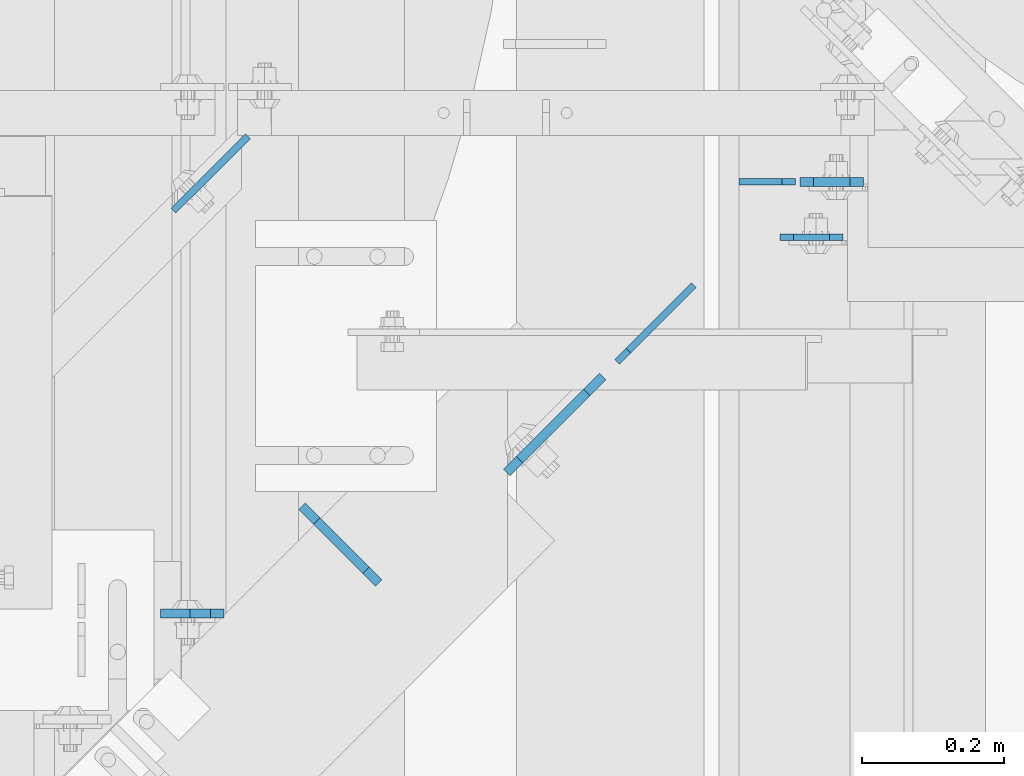
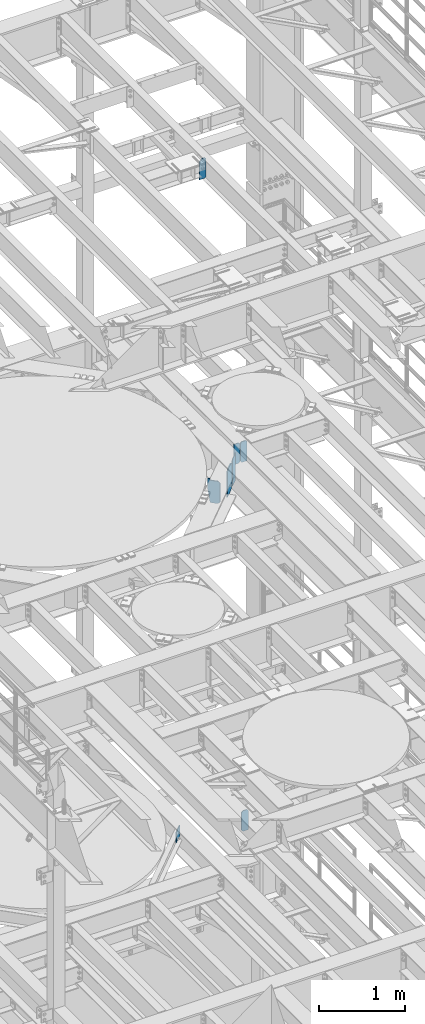
# One storey, part 1786 of 1876: 8 plates, 6 elements without a shape of their own.
"""IFC2X3 building model written with IfcOpenShell, lengths in millimetres."""

from ifc_helpers import new_model, si_unit, frame, origin_with_axes, place, context, subcontext, project, spatial, faceted_brep, material, type_object, element, aggregate, save


model = new_model("IFC2X3")

# Units and contexts
model_context = context("Model", 3, precision=1e-05, world=origin_with_axes())
body_context = subcontext(model_context, "Body", "Model", "MODEL_VIEW")
ifc_project = project(units=[si_unit("LENGTHUNIT", "METRE", prefix="MILLI"), si_unit("AREAUNIT", "SQUARE_METRE"), si_unit("VOLUMEUNIT", "CUBIC_METRE"), si_unit("MASSUNIT", "GRAM", prefix="KILO"), si_unit("TIMEUNIT", "SECOND"), si_unit("PLANEANGLEUNIT", "RADIAN"), si_unit("SOLIDANGLEUNIT", "STERADIAN"), si_unit("THERMODYNAMICTEMPERATUREUNIT", "DEGREE_CELSIUS"), si_unit("LUMINOUSINTENSITYUNIT", "LUMEN")], contexts=[model_context])

# Site, building, storey
site_placement = place(None, origin_with_axes())
site = spatial("IfcSite", under=ifc_project, at=site_placement, CompositionType="ELEMENT")
building_placement = place(site_placement, origin_with_axes())
building = spatial("IfcBuilding", under=site, at=building_placement, Name="Undefined", CompositionType="ELEMENT")
storey_placement = place(building_placement, origin_with_axes())
storey = spatial("IfcBuildingStorey", under=building, at=storey_placement, Name="Undefined", CompositionType="ELEMENT", Elevation=0.0)

# Assembly, plate
assembly_1_placement = place(storey_placement, origin_with_axes())
assembly_1 = element("IfcElementAssembly", 1, at=assembly_1_placement, inside=storey, Name="BEAM", AssemblyPlace="NOTDEFINED", PredefinedType="RIGID_FRAME")
ifc_material = material(Name="STEEL/A36")
plate_type_1 = type_object("IfcPlateType", PredefinedType="NOTDEFINED")
plate_1_placement = place(assembly_1_placement, frame((5489.575, 10802.9379999161, 7851.775), z_axis=(0.0, 0.0, 1.0), x_axis=(1.0, 0.0, 0.0)))
plate_1 = element("IfcPlate", 2, at=plate_1_placement, type_object=plate_type_1, material=ifc_material, Name="PLATE", context=body_context, shape_type="Brep", body=[
    faceted_brep([(0.0, -4.76249999999982, 19.0499992370605), (0.0, -4.76249999999982, 271.462512969971), (0.0, 4.76249999999982, 271.462512969971), (0.0, 4.76249999999982, 19.0499992370605), (19.0499992370605, -4.76249999999982, 290.512512207031), (19.0499992370605, 4.76249999999982, 290.512512207031), (69.8500022888184, -4.76250000000073, 290.512512207031), (69.8500022888184, 4.76250000000073, 290.512512207031), (88.9000015258789, -4.76250000000073, 271.462512969971), (88.9000015258789, 4.76250000000073, 271.462512969971), (88.9000015258789, -4.76249999999982, 0.0), (88.9000015258789, 4.76249999999982, 0.0), (19.0499992370605, -4.76249999999982, 0.0), (19.0499992370605, 4.76249999999982, 0.0)], [[[0, 1, 2, 3]], [[1, 4, 5, 2]], [[4, 6, 7, 5]], [[6, 8, 9, 7]], [[8, 10, 11, 9]], [[10, 12, 13, 11]], [[12, 0, 3, 13]], [[5, 7, 9, 11, 13, 3, 2]], [[12, 10, 8, 6, 4, 1, 0]]]),
])
aggregate(assembly_1, [plate_1])

assembly_2_placement = place(storey_placement, origin_with_axes())
assembly_2 = element("IfcElementAssembly", 3, at=assembly_2_placement, inside=storey, Name="BEAM", AssemblyPlace="NOTDEFINED", PredefinedType="RIGID_FRAME")
plate_type_2 = type_object("IfcPlateType", PredefinedType="NOTDEFINED")
plate_2_placement = place(assembly_2_placement, frame((4708.525, 10274.3012879372, 17686.3375), z_axis=(0.0, 0.0, 1.0), x_axis=(-1.0, 0.0, 0.0)))
plate_2 = element("IfcPlate", 4, at=plate_2_placement, type_object=plate_type_2, material=ifc_material, Name="PLATE", context=body_context, shape_type="Brep", body=[
    faceted_brep([(0.0, -6.35000000000036, 271.462512969971), (19.0499992370605, -6.35000000000036, 290.512512207031), (19.0499992370605, 6.35000000000036, 290.512512207031), (0.0, 6.35000000000036, 271.462512969971), (0.0, -6.35000000000196, 19.0499992370605), (0.0, 6.35000000000105, 19.0499992370605), (19.0499992370642, -6.35000000000105, 0.0), (19.0499992370633, 6.35000000000105, 0.0), (88.9000015258789, -6.34999999999991, 0.0), (88.9000015258789, 6.34999999999991, 0.0), (88.9000015258789, -6.35000000000036, 249.237510681152), (47.625, -6.35000000000036, 290.512512207031), (47.625, 6.35000000000036, 290.512512207031), (88.9000015258789, 6.35000000000036, 249.237510681152)], [[[0, 1, 2, 3]], [[4, 0, 3, 5]], [[6, 4, 5, 7]], [[8, 6, 7, 9]], [[6, 8, 10, 11, 1, 0, 4]], [[1, 11, 12, 2]], [[2, 12, 13, 9, 7, 5, 3]], [[10, 8, 9, 13]], [[11, 10, 13, 12]]]),
])
aggregate(assembly_2, [plate_2])

# Assembly, plates
assembly_3_placement = place(storey_placement, origin_with_axes())
assembly_3 = element("IfcElementAssembly", 5, at=assembly_3_placement, inside=storey, Name="BEAM", AssemblyPlace="NOTDEFINED", PredefinedType="RIGID_FRAME")
plate_3_placement = place(assembly_3_placement, frame((5518.15, 10880.6721065215, 13007.975), z_axis=(0.0, 0.0, 1.0), x_axis=(1.0, 0.0, 0.0)))
plate_3 = element("IfcPlate", 6, at=plate_3_placement, type_object=plate_type_2, material=ifc_material, Name="PLATE", context=body_context, shape_type="Brep", body=[
    faceted_brep([(0.0, -6.35000000000196, 19.0499992370605), (0.0, -6.35000000000036, 271.462512969971), (0.0, 6.35000000000036, 271.462512969971), (0.0, 6.35000000000105, 19.0499992370605), (19.0499992370605, -6.35000000000036, 290.512512207031), (19.0499992370605, 6.35000000000036, 290.512512207031), (69.8500003814697, -6.34999999999991, 290.512512207031), (69.8500003814697, 6.34999999999991, 290.512512207031), (88.9000015258789, -6.35000000000036, 271.462512969971), (88.9000015258789, 6.35000000000036, 271.462512969971), (88.9000015258789, -6.34999999999991, 0.0), (88.9000015258789, 6.34999999999991, 0.0), (19.0499992370642, -6.35000000000105, 0.0), (19.0499992370633, 6.35000000000105, 0.0)], [[[0, 1, 2, 3]], [[1, 4, 5, 2]], [[4, 6, 7, 5]], [[6, 8, 9, 7]], [[8, 10, 11, 9]], [[10, 12, 13, 11]], [[12, 0, 3, 13]], [[5, 7, 9, 11, 13, 3, 2]], [[12, 10, 8, 6, 4, 1, 0]]]),
])
plate_type_3 = type_object("IfcPlateType", PredefinedType="NOTDEFINED")
plate_4_placement = place(assembly_3_placement, frame((5511.8, 10880.6726064376, 13007.975), z_axis=(0.0, 0.0, 1.0), x_axis=(-1.0, 0.0, 0.0)))
plate_4 = element("IfcPlate", 7, at=plate_4_placement, type_object=plate_type_3, material=ifc_material, Name="PLATE", context=body_context, shape_type="Brep", body=[
    faceted_brep([(0.0, -4.76249999999982, 19.0499992370605), (0.0, -4.76250000000073, 269.874988555908), (0.0, 4.76250000000073, 269.874988555908), (0.0, 4.76249999999982, 19.0499992370605), (19.0499992370605, -4.76250000000073, 288.924987792969), (19.0499992370605, 4.76250000000073, 288.924987792969), (79.375, -4.76250000000073, 288.924987792969), (79.375, 4.76250000000073, 288.924987792969), (79.375, -4.76250000000073, 0.0), (79.375, 4.76250000000073, 0.0), (19.0499992370605, -4.76249999999982, 0.0), (19.0499992370605, 4.76249999999982, 0.0)], [[[0, 1, 2, 3]], [[1, 4, 5, 2]], [[4, 6, 7, 5]], [[6, 8, 9, 7]], [[8, 10, 11, 9]], [[10, 0, 3, 11]], [[5, 7, 9, 11, 3, 2]], [[10, 8, 6, 4, 1, 0]]]),
])
aggregate(assembly_3, [plate_4, plate_3])

# Assembly, plate
assembly_4_placement = place(storey_placement, origin_with_axes())
assembly_4 = element("IfcElementAssembly", 8, at=assembly_4_placement, inside=storey, Name="BEAM", AssemblyPlace="NOTDEFINED", PredefinedType="RIGID_FRAME")
plate_type_4 = type_object("IfcPlateType", PredefinedType="NOTDEFINED")
plate_5_placement = place(assembly_4_placement, frame((4742.46460209405, 10944.7448640729, 8121.65), z_axis=(-0.707305809668414, -0.706907696668603, 0.0), x_axis=(0.0, 0.0, -1.0)))
plate_5 = element("IfcPlate", 9, at=plate_5_placement, type_object=plate_type_4, material=ifc_material, Name="PLATE", context=body_context, shape_type="Brep", body=[
    faceted_brep([(0.0, -4.76249999999982, 0.0), (0.0, -4.76249999995343, 148.1358184815), (0.0, 4.76250000004256, 148.135818481504), (0.0, 4.76249999999982, 0.0), (152.399993896484, -4.76249999995343, 148.1358184815), (152.399993896484, 4.76250000004256, 148.135818481504), (152.399993896484, -4.76249999999982, 0.0), (152.399993896484, 4.76249999999982, 0.0)], [[[0, 1, 2, 3]], [[1, 4, 5, 2]], [[4, 6, 7, 5]], [[6, 0, 3, 7]], [[5, 7, 3, 2]], [[6, 4, 1, 0]]]),
])
aggregate(assembly_4, [plate_5])

assembly_5_placement = place(storey_placement, origin_with_axes())
assembly_5 = element("IfcElementAssembly", 10, at=assembly_5_placement, inside=storey, Name="BEAM", AssemblyPlace="NOTDEFINED", PredefinedType="RIGID_FRAME")
plate_type_5 = type_object("IfcPlateType", PredefinedType="NOTDEFINED")
plate_6_placement = place(assembly_5_placement, frame((5261.1679479814, 10627.6352239704, 12906.375), z_axis=(0.0, 0.0, 1.0), x_axis=(0.707106781186548, 0.707106781186547, 0.0)))
plate_6 = element("IfcPlate", 11, at=plate_6_placement, type_object=plate_type_5, material=ifc_material, Name="PLATE", context=body_context, shape_type="Brep", body=[
    faceted_brep([(9.09494701772928e-13, -4.76249999999891, 22.2250003814697), (9.09494701772928e-13, -4.76249999999891, 358.77499961853), (-1.81898940354586e-12, 4.76250000000255, 358.77499961853), (-1.81898940354586e-12, 4.76250000000255, 22.2250003814697), (22.2250003814697, -4.76250000000073, 381.0), (22.2250003814688, 4.76249999999709, 381.0), (152.399993896486, -4.76250000002256, 381.0), (152.399993896483, 4.7624999999789, 381.0), (152.399993896484, -4.76249999999982, 0.0), (152.399993896484, 4.76249999999982, 0.0), (22.2250003814697, -4.76250000000073, 0.0), (22.2250003814688, 4.76249999999709, 0.0)], [[[0, 1, 2, 3]], [[1, 4, 5, 2]], [[4, 6, 7, 5]], [[6, 8, 9, 7]], [[8, 10, 11, 9]], [[10, 0, 3, 11]], [[5, 7, 9, 11, 3, 2]], [[10, 8, 6, 4, 1, 0]]]),
])

assembly_6_placement = place(storey_placement, origin_with_axes())
assembly_6 = element("IfcElementAssembly", 12, at=assembly_6_placement, inside=storey, Name="BEAM", AssemblyPlace="NOTDEFINED", PredefinedType="RIGID_FRAME")
plate_type_6 = type_object("IfcPlateType", PredefinedType="NOTDEFINED")
plate_7_placement = place(assembly_6_placement, frame((4926.03506997814, 10317.1987577487, 12974.637), z_axis=(-0.707106781186548, 0.707106781186547, 0.0), x_axis=(0.0, 0.0, 1.0)))
plate_7 = element("IfcPlate", 13, at=plate_7_placement, type_object=plate_type_6, material=ifc_material, Name="PLATE", context=body_context, shape_type="Brep", body=[
    faceted_brep([(0.0, -6.35000000000036, 25.4000000000005), (0.0, -6.35000000001855, 120.650001525881), (0.0, 6.34999999998035, 120.650001525879), (0.0, 6.35000000000036, 25.4000000000005), (207.962997436523, -6.35000000002401, 152.399993896486), (207.962997436523, 6.34999999997581, 152.399993896484), (334.963012695312, -6.35000000002401, 152.399993896486), (334.963012695312, 6.34999999997581, 152.399993896484), (334.963012695312, -6.35000000001946, 123.030746459965), (334.963012695312, 6.34999999998035, 123.030746459961), (315.912994384766, -6.35000000001946, 123.030746459965), (315.912994384766, 6.34999999998035, 123.030746459961), (315.912994384766, -6.35000000000491, 25.3999996183684), (315.912994384766, 6.34999999999582, 25.3999996183666), (290.512994766235, -6.34999999999945, -1.4915713109076e-10), (290.512994766235, 6.35000000000036, -1.52795109897852e-10), (25.3999996185303, -6.34999999999991, 0.0), (25.3999996185303, 6.34999999999991, 0.0)], [[[0, 1, 2, 3]], [[1, 4, 5, 2]], [[4, 6, 7, 5]], [[6, 8, 9, 7]], [[8, 10, 11, 9]], [[10, 12, 13, 11]], [[12, 14, 15, 13]], [[14, 16, 17, 15]], [[16, 0, 3, 17]], [[5, 7, 9, 11, 13, 15, 17, 3, 2]], [[16, 14, 12, 10, 8, 6, 4, 1, 0]]]),
])
aggregate(assembly_6, [plate_7])

# Plate
plate_type_7 = type_object("IfcPlateType", PredefinedType="NOTDEFINED")
plate_8_placement = place(assembly_5_placement, frame((5240.6098704544, 10607.0778533287, 12907.9625), z_axis=(0.0, 0.0, 1.0), x_axis=(-0.707106781186547, -0.707106781186548, 0.0)))
plate_8 = element("IfcPlate", 14, at=plate_8_placement, type_object=plate_type_7, material=ifc_material, Name="PLATE", context=body_context, shape_type="Brep", body=[
    faceted_brep([(0.0, -6.34999999999991, 31.75), (9.09494701772928e-13, -6.35000000000036, 347.662506103516), (-9.09494701772928e-13, 6.35000000000036, 347.662506103516), (0.0, 6.34999999999991, 31.75), (31.7500000000055, -6.35000000000036, 379.412506103516), (31.7500000000055, 6.35000000000036, 379.412506103516), (165.100000381499, -6.35000000000036, 379.412506103516), (165.100000381497, 6.35000000000036, 379.412506103516), (190.500000000031, -6.35000000000036, 354.012506484985), (190.500000000034, 6.35000000000036, 354.012506484985), (190.500000000031, -6.35000000000036, 0.0), (190.500000000034, 6.35000000000036, 0.0), (31.75, -6.34999999999991, 0.0), (31.75, 6.34999999999991, 0.0)], [[[0, 1, 2, 3]], [[1, 4, 5, 2]], [[4, 6, 7, 5]], [[6, 8, 9, 7]], [[8, 10, 11, 9]], [[10, 12, 13, 11]], [[12, 0, 3, 13]], [[5, 7, 9, 11, 13, 3, 2]], [[12, 10, 8, 6, 4, 1, 0]]]),
])

aggregate(assembly_5, [plate_6, plate_8])

save(model, "model.ifc")
